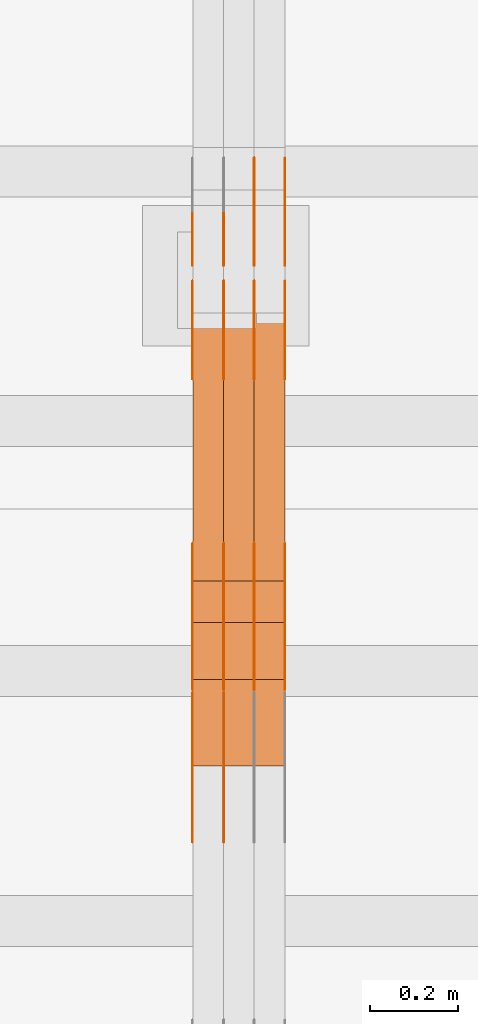
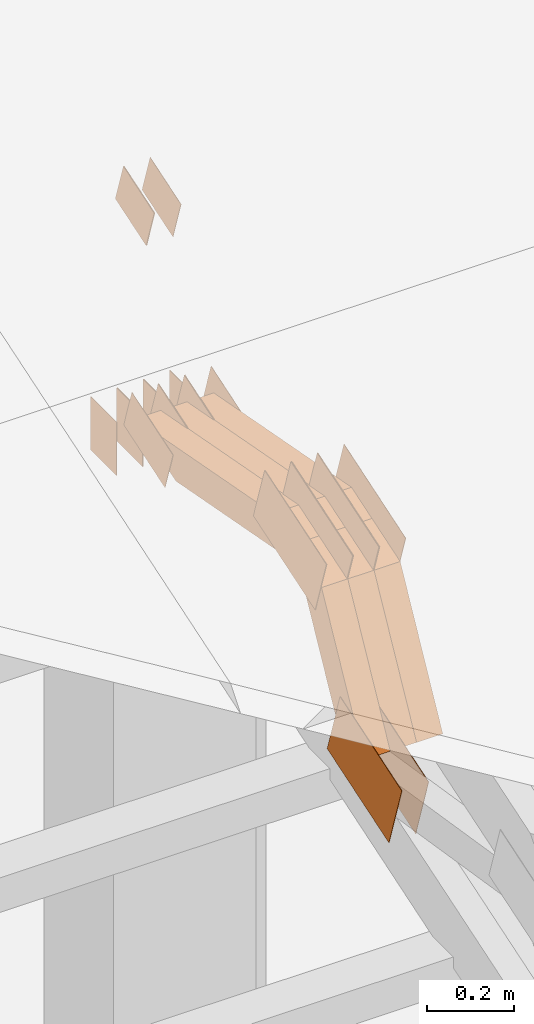
# One storey, part 297 of 385: 29 proxies.
"""IFC2X3 building model written with IfcOpenShell, lengths in millimetres."""

from ifc_helpers import new_model, entity, si_unit, converted_unit, derived_unit, direction, frame, frame_2d, origin, place, context, subcontext, project, spatial, polyline, rectangle, outline, extrude, source, transform, mapped, material, type_object, type_shapes, element, save


model = new_model("IFC2X3")

# Units and contexts
model_context = context("Model", 3, precision=0.01, world=origin(), true_north=direction((6.12303176911189e-17, 1.0)))
body_context = subcontext(model_context, "Body", "Model", "MODEL_VIEW")
ifc_project = project(units=[si_unit("LENGTHUNIT", "METRE", prefix="MILLI"), si_unit("AREAUNIT", "SQUARE_METRE"), si_unit("VOLUMEUNIT", "CUBIC_METRE"), converted_unit("PLANEANGLEUNIT", "DEGREE", entity("IfcRatioMeasure", 0.0174532925199433), si_unit("PLANEANGLEUNIT", "RADIAN"), dimensions=[0, 0, 0, 0, 0, 0, 0]), si_unit("MASSUNIT", "GRAM", prefix="KILO"), derived_unit("MASSDENSITYUNIT", [(si_unit("MASSUNIT", "GRAM", prefix="KILO"), 1), (si_unit("LENGTHUNIT", "METRE"), -3)]), si_unit("TIMEUNIT", "SECOND"), si_unit("FREQUENCYUNIT", "HERTZ"), si_unit("THERMODYNAMICTEMPERATUREUNIT", "DEGREE_CELSIUS"), derived_unit("THERMALTRANSMITTANCEUNIT", [(si_unit("MASSUNIT", "GRAM", prefix="KILO"), 1), (si_unit("THERMODYNAMICTEMPERATUREUNIT", "KELVIN"), -1), (si_unit("TIMEUNIT", "SECOND"), -3)]), derived_unit("VOLUMETRICFLOWRATEUNIT", [(si_unit("LENGTHUNIT", "METRE"), 3), (si_unit("TIMEUNIT", "SECOND"), -1)]), si_unit("ELECTRICCURRENTUNIT", "AMPERE"), si_unit("ELECTRICVOLTAGEUNIT", "VOLT"), si_unit("POWERUNIT", "WATT"), si_unit("FORCEUNIT", "NEWTON", prefix="KILO"), si_unit("ILLUMINANCEUNIT", "LUX"), si_unit("LUMINOUSFLUXUNIT", "LUMEN"), si_unit("LUMINOUSINTENSITYUNIT", "CANDELA"), derived_unit("USERDEFINED", [(si_unit("MASSUNIT", "GRAM", prefix="KILO"), -1), (si_unit("LENGTHUNIT", "METRE"), -2), (si_unit("TIMEUNIT", "SECOND"), 3), (si_unit("LUMINOUSFLUXUNIT", "LUMEN"), 1)]), derived_unit("LINEARVELOCITYUNIT", [(si_unit("LENGTHUNIT", "METRE"), 1), (si_unit("TIMEUNIT", "SECOND"), -1)]), si_unit("PRESSUREUNIT", "PASCAL"), derived_unit("USERDEFINED", [(si_unit("LENGTHUNIT", "METRE"), -2), (si_unit("MASSUNIT", "GRAM", prefix="KILO"), 1), (si_unit("TIMEUNIT", "SECOND"), -2)])], contexts=[model_context])

# Site, building, storey
site_placement = place(None, origin())
site = spatial("IfcSite", under=ifc_project, at=site_placement, CompositionType="ELEMENT")
building_placement = place(site_placement, origin())
building = spatial("IfcBuilding", under=site, at=building_placement, CompositionType="ELEMENT")
storey_placement = place(building_placement, origin())
storey = spatial("IfcBuildingStorey", under=building, at=storey_placement, Name="Default", CompositionType="ELEMENT", Elevation=0.0)

# Proxies
ifc_material_1 = material(Name="IfcSurfaceStyle #552548")
building_element_proxy_type_1 = type_object("IfcBuildingElementProxyType", PredefinedType="NOTDEFINED", material=ifc_material_1)
shared_shape_1 = source(origin(), body_context, "Body", "SweptSolid", [
    extrude(outline(polyline([(-149.99966632326, -95.9999759039407), (149.999881095801, -95.9999759039407), (150.000557367591, 95.9999759039407), (-150.000772140132, 95.9999759039406), (-149.99966632326, -95.9999759039407)])), frame((150.000557367591, 96.0004291135906, 0.0), z_axis=(0.0, 0.0, 1.0), x_axis=(-1.0, 0.0, 0.0)), (0.0, 0.0, 1.0), 1.29999999999998),
])
type_shapes(building_element_proxy_type_1, [shared_shape_1])
proxy_1_placement = place(building_placement, frame((45246.3, 10934.7734375, 2766.8759765625), z_axis=(-1.0, 0.0, 0.0), x_axis=(0.0, 0.951056516295124, 0.309016994375039)))
element("IfcBuildingElementProxy", 1, at=proxy_1_placement, inside=storey, type_object=building_element_proxy_type_1, material=ifc_material_1, context=body_context, shape_type="MappedRepresentation", body=[
    mapped(shared_shape_1, transform((0.0, 0.0, 0.0), scale=1.0)),
])
ifc_material_2 = material(Name="IfcSurfaceStyle #552491")
building_element_proxy_type_2 = type_object("IfcBuildingElementProxyType", PredefinedType="NOTDEFINED", material=ifc_material_2)
shared_shape_2 = source(origin(), body_context, "Body", "SweptSolid", [
    extrude(outline(polyline([(-149.99966632326, -95.9999759039407), (149.999881095801, -95.9999759039407), (150.000557367591, 95.9999759039407), (-150.000772140132, 95.9999759039406), (-149.99966632326, -95.9999759039407)])), frame((150.000557367591, 96.0004291135906, 0.0), z_axis=(0.0, 0.0, 1.0), x_axis=(-1.0, 0.0, 0.0)), (0.0, 0.0, 1.0), 1.29999999999998),
])
type_shapes(building_element_proxy_type_2, [shared_shape_2])
proxy_2_placement = place(building_placement, frame((45175.0, 10934.7734375, 2766.8759765625), z_axis=(-1.0, 0.0, 0.0), x_axis=(0.0, 0.951056516295124, 0.309016994375039)))
element("IfcBuildingElementProxy", 2, at=proxy_2_placement, inside=storey, type_object=building_element_proxy_type_2, material=ifc_material_2, context=body_context, shape_type="MappedRepresentation", body=[
    mapped(shared_shape_2, transform((0.0, 0.0, 0.0), scale=1.0)),
])
ifc_material_3 = material(Name="IfcSurfaceStyle #551408")
building_element_proxy_type_3 = type_object("IfcBuildingElementProxyType", PredefinedType="NOTDEFINED", material=ifc_material_3)
shared_shape_3 = source(origin(), body_context, "Body", "SweptSolid", [
    extrude(outline(polyline([(-99.9997874178038, -60.0000528641967), (99.9998102700997, -60.0000528641967), (99.9998251396068, 60.0000528641967), (-99.9998479919027, 60.0000528641967), (-99.9997874178038, -60.0000528641967)])), frame((99.9999918898597, 60.0000528641967, 0.0), z_axis=(0.0, 0.0, 1.0), x_axis=(-1.0, 0.0, 0.0)), (0.0, 0.0, 1.0), 1.3),
])
type_shapes(building_element_proxy_type_3, [shared_shape_3])
proxy_3_placement = place(building_placement, frame((45386.3, 11991.9568177725, 3072.52282247925), z_axis=(-1.0, 0.0, 0.0), x_axis=(0.0, 0.951056516295124, 0.309016994375039)))
element("IfcBuildingElementProxy", 3, at=proxy_3_placement, inside=storey, type_object=building_element_proxy_type_3, material=ifc_material_3, context=body_context, shape_type="MappedRepresentation", body=[
    mapped(shared_shape_3, transform((0.0, 0.0, 0.0), scale=1.0)),
])
ifc_material_4 = material(Name="IfcSurfaceStyle #551351")
building_element_proxy_type_4 = type_object("IfcBuildingElementProxyType", PredefinedType="NOTDEFINED", material=ifc_material_4)
shared_shape_4 = source(origin(), body_context, "Body", "SweptSolid", [
    extrude(outline(polyline([(-99.9997874178038, -60.0000528641967), (99.9998102700997, -60.0000528641967), (99.9998251396068, 60.0000528641967), (-99.9998479919027, 60.0000528641967), (-99.9997874178038, -60.0000528641967)])), frame((99.9999918898597, 60.0000528641967, 0.0), z_axis=(0.0, 0.0, 1.0), x_axis=(-1.0, 0.0, 0.0)), (0.0, 0.0, 1.0), 1.3),
])
type_shapes(building_element_proxy_type_4, [shared_shape_4])
proxy_4_placement = place(building_placement, frame((45315.0, 11991.9568177725, 3072.52282247925), z_axis=(-1.0, 0.0, 0.0), x_axis=(0.0, 0.951056516295124, 0.309016994375039)))
element("IfcBuildingElementProxy", 4, at=proxy_4_placement, inside=storey, type_object=building_element_proxy_type_4, material=ifc_material_4, context=body_context, shape_type="MappedRepresentation", body=[
    mapped(shared_shape_4, transform((0.0, 0.0, 0.0), scale=1.0)),
])
ifc_material_5 = material(Name="IfcSurfaceStyle #551294")
building_element_proxy_type_5 = type_object("IfcBuildingElementProxyType", PredefinedType="NOTDEFINED", material=ifc_material_5)
shared_shape_5 = source(origin(), body_context, "Body", "SweptSolid", [
    extrude(outline(polyline([(-99.9997874178038, -60.0000528641967), (99.9998102700997, -60.0000528641967), (99.9998251396068, 60.0000528641967), (-99.9998479919027, 60.0000528641967), (-99.9997874178038, -60.0000528641967)])), frame((99.9999918898597, 60.0000528641967, 0.0), z_axis=(0.0, 0.0, 1.0), x_axis=(-1.0, 0.0, 0.0)), (0.0, 0.0, 1.0), 1.3),
])
type_shapes(building_element_proxy_type_5, [shared_shape_5])
proxy_5_placement = place(building_placement, frame((45316.3, 11991.9568177725, 3072.52282247925), z_axis=(-1.0, 0.0, 0.0), x_axis=(0.0, 0.951056516295124, 0.309016994375039)))
element("IfcBuildingElementProxy", 5, at=proxy_5_placement, inside=storey, type_object=building_element_proxy_type_5, material=ifc_material_5, context=body_context, shape_type="MappedRepresentation", body=[
    mapped(shared_shape_5, transform((0.0, 0.0, 0.0), scale=1.0)),
])
ifc_material_6 = material(Name="IfcSurfaceStyle #551237")
building_element_proxy_type_6 = type_object("IfcBuildingElementProxyType", PredefinedType="NOTDEFINED", material=ifc_material_6)
shared_shape_6 = source(origin(), body_context, "Body", "SweptSolid", [
    extrude(outline(polyline([(-99.9997874178038, -60.0000528641967), (99.9998102700997, -60.0000528641967), (99.9998251396068, 60.0000528641967), (-99.9998479919027, 60.0000528641967), (-99.9997874178038, -60.0000528641967)])), frame((99.9999918898597, 60.0000528641967, 0.0), z_axis=(0.0, 0.0, 1.0), x_axis=(-1.0, 0.0, 0.0)), (0.0, 0.0, 1.0), 1.29999999999998),
])
type_shapes(building_element_proxy_type_6, [shared_shape_6])
proxy_6_placement = place(building_placement, frame((45245.0, 11991.9568177725, 3072.52282247925), z_axis=(-1.0, 0.0, 0.0), x_axis=(0.0, 0.951056516295124, 0.309016994375039)))
element("IfcBuildingElementProxy", 6, at=proxy_6_placement, inside=storey, type_object=building_element_proxy_type_6, material=ifc_material_6, context=body_context, shape_type="MappedRepresentation", body=[
    mapped(shared_shape_6, transform((0.0, 0.0, 0.0), scale=1.0)),
])
ifc_material_7 = material(Name="IfcSurfaceStyle #551180")
building_element_proxy_type_7 = type_object("IfcBuildingElementProxyType", PredefinedType="NOTDEFINED", material=ifc_material_7)
shared_shape_7 = source(origin(), body_context, "Body", "SweptSolid", [
    extrude(outline(polyline([(-99.9997874178038, -60.0000528641967), (99.9998102700997, -60.0000528641967), (99.9998251396068, 60.0000528641967), (-99.9998479919027, 60.0000528641967), (-99.9997874178038, -60.0000528641967)])), frame((99.9999918898597, 60.0000528641967, 0.0), z_axis=(0.0, 0.0, 1.0), x_axis=(-1.0, 0.0, 0.0)), (0.0, 0.0, 1.0), 1.29999999999998),
])
type_shapes(building_element_proxy_type_7, [shared_shape_7])
proxy_7_placement = place(building_placement, frame((45246.3, 11991.9568177725, 3072.52282247925), z_axis=(-1.0, 0.0, 0.0), x_axis=(0.0, 0.951056516295124, 0.309016994375039)))
element("IfcBuildingElementProxy", 7, at=proxy_7_placement, inside=storey, type_object=building_element_proxy_type_7, material=ifc_material_7, context=body_context, shape_type="MappedRepresentation", body=[
    mapped(shared_shape_7, transform((0.0, 0.0, 0.0), scale=1.0)),
])
ifc_material_8 = material(Name="IfcSurfaceStyle #551123")
building_element_proxy_type_8 = type_object("IfcBuildingElementProxyType", PredefinedType="NOTDEFINED", material=ifc_material_8)
shared_shape_8 = source(origin(), body_context, "Body", "SweptSolid", [
    extrude(outline(polyline([(-99.9997874178038, -60.0000528641967), (99.9998102700997, -60.0000528641967), (99.9998251396068, 60.0000528641967), (-99.9998479919027, 60.0000528641967), (-99.9997874178038, -60.0000528641967)])), frame((99.9999918898597, 60.0000528641967, 0.0), z_axis=(0.0, 0.0, 1.0), x_axis=(-1.0, 0.0, 0.0)), (0.0, 0.0, 1.0), 1.29999999999999),
])
type_shapes(building_element_proxy_type_8, [shared_shape_8])
proxy_8_placement = place(building_placement, frame((45175.0, 11991.9568177725, 3072.52282247925), z_axis=(-1.0, 0.0, 0.0), x_axis=(0.0, 0.951056516295124, 0.309016994375039)))
element("IfcBuildingElementProxy", 8, at=proxy_8_placement, inside=storey, type_object=building_element_proxy_type_8, material=ifc_material_8, context=body_context, shape_type="MappedRepresentation", body=[
    mapped(shared_shape_8, transform((0.0, 0.0, 0.0), scale=1.0)),
])
ifc_material_9 = material(Name="IfcSurfaceStyle #551066")
building_element_proxy_type_9 = type_object("IfcBuildingElementProxyType", PredefinedType="NOTDEFINED", material=ifc_material_9)
shared_shape_9 = source(origin(), body_context, "Body", "SweptSolid", [
    extrude(rectangle(XDim=150.0, YDim=119.999999999985, at=frame_2d((-7.105427357601e-15, 0.0), x_axis=(1.0, 0.0))), frame((75.0, 60.0, 0.0), z_axis=(0.0, 0.0, 1.0), x_axis=(-1.0, 0.0, 0.0)), (0.0, 0.0, 1.0), 1.3),
])
type_shapes(building_element_proxy_type_9, [shared_shape_9])
proxy_9_placement = place(building_placement, frame((45386.3, 12372.95703125, 3007.04687500001), z_axis=(-1.0, 0.0, 0.0), x_axis=(0.0, 0.0, -1.0)))
element("IfcBuildingElementProxy", 9, at=proxy_9_placement, inside=storey, type_object=building_element_proxy_type_9, material=ifc_material_9, context=body_context, shape_type="MappedRepresentation", body=[
    mapped(shared_shape_9, transform((0.0, 0.0, 0.0), scale=1.0)),
])
ifc_material_10 = material(Name="IfcSurfaceStyle #551009")
building_element_proxy_type_10 = type_object("IfcBuildingElementProxyType", PredefinedType="NOTDEFINED", material=ifc_material_10)
shared_shape_10 = source(origin(), body_context, "Body", "SweptSolid", [
    extrude(rectangle(XDim=150.0, YDim=119.999999999985, at=frame_2d((-7.105427357601e-15, 0.0), x_axis=(1.0, 0.0))), frame((75.0, 60.0, 0.0), z_axis=(0.0, 0.0, 1.0), x_axis=(-1.0, 0.0, 0.0)), (0.0, 0.0, 1.0), 1.3),
])
type_shapes(building_element_proxy_type_10, [shared_shape_10])
proxy_10_placement = place(building_placement, frame((45315.0, 12372.95703125, 3007.04687500001), z_axis=(-1.0, 0.0, 0.0), x_axis=(0.0, 0.0, -1.0)))
element("IfcBuildingElementProxy", 10, at=proxy_10_placement, inside=storey, type_object=building_element_proxy_type_10, material=ifc_material_10, context=body_context, shape_type="MappedRepresentation", body=[
    mapped(shared_shape_10, transform((0.0, 0.0, 0.0), scale=1.0)),
])
ifc_material_11 = material(Name="IfcSurfaceStyle #550952")
building_element_proxy_type_11 = type_object("IfcBuildingElementProxyType", PredefinedType="NOTDEFINED", material=ifc_material_11)
shared_shape_11 = source(origin(), body_context, "Body", "SweptSolid", [
    extrude(rectangle(XDim=150.0, YDim=119.999999999985, at=frame_2d((-7.105427357601e-15, 0.0), x_axis=(1.0, 0.0))), frame((75.0, 60.0, 0.0), z_axis=(0.0, 0.0, 1.0), x_axis=(-1.0, 0.0, 0.0)), (0.0, 0.0, 1.0), 1.3),
])
type_shapes(building_element_proxy_type_11, [shared_shape_11])
proxy_11_placement = place(building_placement, frame((45316.3, 12372.95703125, 3007.04687500001), z_axis=(-1.0, 0.0, 0.0), x_axis=(0.0, 0.0, -1.0)))
element("IfcBuildingElementProxy", 11, at=proxy_11_placement, inside=storey, type_object=building_element_proxy_type_11, material=ifc_material_11, context=body_context, shape_type="MappedRepresentation", body=[
    mapped(shared_shape_11, transform((0.0, 0.0, 0.0), scale=1.0)),
])
ifc_material_12 = material(Name="IfcSurfaceStyle #550895")
building_element_proxy_type_12 = type_object("IfcBuildingElementProxyType", PredefinedType="NOTDEFINED", material=ifc_material_12)
shared_shape_12 = source(origin(), body_context, "Body", "SweptSolid", [
    extrude(rectangle(XDim=150.0, YDim=119.999999999985, at=frame_2d((-7.105427357601e-15, 0.0), x_axis=(1.0, 0.0))), frame((75.0, 60.0, 0.0), z_axis=(0.0, 0.0, 1.0), x_axis=(-1.0, 0.0, 0.0)), (0.0, 0.0, 1.0), 1.29999999999999),
])
type_shapes(building_element_proxy_type_12, [shared_shape_12])
proxy_12_placement = place(building_placement, frame((45245.0, 12372.95703125, 3007.04687500001), z_axis=(-1.0, 0.0, 0.0), x_axis=(0.0, 0.0, -1.0)))
element("IfcBuildingElementProxy", 12, at=proxy_12_placement, inside=storey, type_object=building_element_proxy_type_12, material=ifc_material_12, context=body_context, shape_type="MappedRepresentation", body=[
    mapped(shared_shape_12, transform((0.0, 0.0, 0.0), scale=1.0)),
])
ifc_material_13 = material(Name="IfcSurfaceStyle #550838")
building_element_proxy_type_13 = type_object("IfcBuildingElementProxyType", PredefinedType="NOTDEFINED", material=ifc_material_13)
shared_shape_13 = source(origin(), body_context, "Body", "SweptSolid", [
    extrude(rectangle(XDim=150.0, YDim=119.999999999985, at=frame_2d((-7.105427357601e-15, 0.0), x_axis=(1.0, 0.0))), frame((75.0, 60.0, 0.0), z_axis=(0.0, 0.0, 1.0), x_axis=(-1.0, 0.0, 0.0)), (0.0, 0.0, 1.0), 1.29999999999999),
])
type_shapes(building_element_proxy_type_13, [shared_shape_13])
proxy_13_placement = place(building_placement, frame((45246.3, 12372.95703125, 3007.04687500001), z_axis=(-1.0, 0.0, 0.0), x_axis=(0.0, 0.0, -1.0)))
element("IfcBuildingElementProxy", 13, at=proxy_13_placement, inside=storey, type_object=building_element_proxy_type_13, material=ifc_material_13, context=body_context, shape_type="MappedRepresentation", body=[
    mapped(shared_shape_13, transform((0.0, 0.0, 0.0), scale=1.0)),
])
ifc_material_14 = material(Name="IfcSurfaceStyle #550781")
building_element_proxy_type_14 = type_object("IfcBuildingElementProxyType", PredefinedType="NOTDEFINED", material=ifc_material_14)
shared_shape_14 = source(origin(), body_context, "Body", "SweptSolid", [
    extrude(rectangle(XDim=150.0, YDim=119.999999999985, at=frame_2d((-7.105427357601e-15, 0.0), x_axis=(1.0, 0.0))), frame((75.0, 60.0, 0.0), z_axis=(0.0, 0.0, 1.0), x_axis=(-1.0, 0.0, 0.0)), (0.0, 0.0, 1.0), 1.29999999999999),
])
type_shapes(building_element_proxy_type_14, [shared_shape_14])
proxy_14_placement = place(building_placement, frame((45175.0, 12372.95703125, 3007.04687500001), z_axis=(-1.0, 0.0, 0.0), x_axis=(0.0, 0.0, -1.0)))
element("IfcBuildingElementProxy", 14, at=proxy_14_placement, inside=storey, type_object=building_element_proxy_type_14, material=ifc_material_14, context=body_context, shape_type="MappedRepresentation", body=[
    mapped(shared_shape_14, transform((0.0, 0.0, 0.0), scale=1.0)),
])
ifc_material_15 = material(Name="IfcSurfaceStyle #543884")
building_element_proxy_type_15 = type_object("IfcBuildingElementProxyType", PredefinedType="NOTDEFINED", material=ifc_material_15)
shared_shape_15 = source(origin(), body_context, "Body", "SweptSolid", [
    extrude(outline(polyline([(-74.9998754286244, -60.0000016373506), (74.9998605591063, -60.0000016373506), (74.9998754286244, 60.0000016373506), (-74.9998605591063, 60.0000016373506), (-74.9998754286244, -60.0000016373506)])), frame((74.9998754286244, 60.0000016373506, 0.0), z_axis=(0.0, 0.0, 1.0), x_axis=(-1.0, 0.0, 0.0)), (0.0, 0.0, 1.0), 1.3),
])
type_shapes(building_element_proxy_type_15, [shared_shape_15])
proxy_15_placement = place(building_placement, frame((45386.3, 12321.1620861463, 3506.17707344366), z_axis=(-1.0, 0.0, 0.0), x_axis=(0.0, 0.951056516295154, 0.309016994374948)))
element("IfcBuildingElementProxy", 15, at=proxy_15_placement, inside=storey, type_object=building_element_proxy_type_15, material=ifc_material_15, context=body_context, shape_type="MappedRepresentation", body=[
    mapped(shared_shape_15, transform((0.0, 0.0, 0.0), scale=1.0)),
])
ifc_material_16 = material(Name="IfcSurfaceStyle #543827")
building_element_proxy_type_16 = type_object("IfcBuildingElementProxyType", PredefinedType="NOTDEFINED", material=ifc_material_16)
shared_shape_16 = source(origin(), body_context, "Body", "SweptSolid", [
    extrude(outline(polyline([(-74.9998754286244, -60.0000016373506), (74.9998605591063, -60.0000016373506), (74.9998754286244, 60.0000016373506), (-74.9998605591063, 60.0000016373506), (-74.9998754286244, -60.0000016373506)])), frame((74.9998754286244, 60.0000016373506, 0.0), z_axis=(0.0, 0.0, 1.0), x_axis=(-1.0, 0.0, 0.0)), (0.0, 0.0, 1.0), 1.3),
])
type_shapes(building_element_proxy_type_16, [shared_shape_16])
proxy_16_placement = place(building_placement, frame((45315.0, 12321.1620861463, 3506.17707344366), z_axis=(-1.0, 0.0, 0.0), x_axis=(0.0, 0.951056516295154, 0.309016994374948)))
element("IfcBuildingElementProxy", 16, at=proxy_16_placement, inside=storey, type_object=building_element_proxy_type_16, material=ifc_material_16, context=body_context, shape_type="MappedRepresentation", body=[
    mapped(shared_shape_16, transform((0.0, 0.0, 0.0), scale=1.0)),
])
ifc_material_17 = material(Name="IfcSurfaceStyle #543770")
building_element_proxy_type_17 = type_object("IfcBuildingElementProxyType", PredefinedType="NOTDEFINED", material=ifc_material_17)
shared_shape_17 = source(origin(), body_context, "Body", "SweptSolid", [
    extrude(outline(polyline([(-74.9998754286244, -60.0000016373506), (74.9998605591063, -60.0000016373506), (74.9998754286244, 60.0000016373506), (-74.9998605591063, 60.0000016373506), (-74.9998754286244, -60.0000016373506)])), frame((74.9998754286244, 60.0000016373506, 0.0), z_axis=(0.0, 0.0, 1.0), x_axis=(-1.0, 0.0, 0.0)), (0.0, 0.0, 1.0), 1.3),
])
type_shapes(building_element_proxy_type_17, [shared_shape_17])
proxy_17_placement = place(building_placement, frame((45316.3, 12321.1620861463, 3506.17707344366), z_axis=(-1.0, 0.0, 0.0), x_axis=(0.0, 0.951056516295154, 0.309016994374948)))
element("IfcBuildingElementProxy", 17, at=proxy_17_placement, inside=storey, type_object=building_element_proxy_type_17, material=ifc_material_17, context=body_context, shape_type="MappedRepresentation", body=[
    mapped(shared_shape_17, transform((0.0, 0.0, 0.0), scale=1.0)),
])
ifc_material_18 = material(Name="IfcSurfaceStyle #543200")
building_element_proxy_type_18 = type_object("IfcBuildingElementProxyType", PredefinedType="NOTDEFINED", material=ifc_material_18)
shared_shape_18 = source(origin(), body_context, "Body", "SweptSolid", [
    extrude(outline(polyline([(-150.000273478628, -84.0002987844282), (149.999198496832, -84.0002987844282), (150.000273478627, 84.0002987844282), (-149.999198496831, 84.0002987844282), (-150.000273478628, -84.0002987844282)])), frame((150.000273478627, 84.0002987844282, 0.0), z_axis=(0.0, 0.0, 1.0), x_axis=(-1.0, 0.0, 0.0)), (0.0, 0.0, 1.0), 1.29999999999999),
])
type_shapes(building_element_proxy_type_18, [shared_shape_18])
proxy_18_placement = place(building_placement, frame((45386.3, 11283.0116722926, 3194.09682266857), z_axis=(-1.0, 0.0, 0.0), x_axis=(0.0, 0.951056516295154, 0.309016994374948)))
element("IfcBuildingElementProxy", 18, at=proxy_18_placement, inside=storey, type_object=building_element_proxy_type_18, material=ifc_material_18, context=body_context, shape_type="MappedRepresentation", body=[
    mapped(shared_shape_18, transform((0.0, 0.0, 0.0), scale=1.0)),
])
ifc_material_19 = material(Name="IfcSurfaceStyle #543143")
building_element_proxy_type_19 = type_object("IfcBuildingElementProxyType", PredefinedType="NOTDEFINED", material=ifc_material_19)
shared_shape_19 = source(origin(), body_context, "Body", "SweptSolid", [
    extrude(outline(polyline([(-150.000273478628, -84.0002987844282), (149.999198496832, -84.0002987844282), (150.000273478627, 84.0002987844282), (-149.999198496831, 84.0002987844282), (-150.000273478628, -84.0002987844282)])), frame((150.000273478627, 84.0002987844282, 0.0), z_axis=(0.0, 0.0, 1.0), x_axis=(-1.0, 0.0, 0.0)), (0.0, 0.0, 1.0), 1.29999999999999),
])
type_shapes(building_element_proxy_type_19, [shared_shape_19])
proxy_19_placement = place(building_placement, frame((45315.0, 11283.0116722926, 3194.09682266857), z_axis=(-1.0, 0.0, 0.0), x_axis=(0.0, 0.951056516295154, 0.309016994374948)))
element("IfcBuildingElementProxy", 19, at=proxy_19_placement, inside=storey, type_object=building_element_proxy_type_19, material=ifc_material_19, context=body_context, shape_type="MappedRepresentation", body=[
    mapped(shared_shape_19, transform((0.0, 0.0, 0.0), scale=1.0)),
])
ifc_material_20 = material(Name="IfcSurfaceStyle #543086")
building_element_proxy_type_20 = type_object("IfcBuildingElementProxyType", PredefinedType="NOTDEFINED", material=ifc_material_20)
shared_shape_20 = source(origin(), body_context, "Body", "SweptSolid", [
    extrude(outline(polyline([(-150.000273478628, -84.0002987844282), (149.999198496832, -84.0002987844282), (150.000273478627, 84.0002987844282), (-149.999198496831, 84.0002987844282), (-150.000273478628, -84.0002987844282)])), frame((150.000273478627, 84.0002987844282, 0.0), z_axis=(0.0, 0.0, 1.0), x_axis=(-1.0, 0.0, 0.0)), (0.0, 0.0, 1.0), 1.29999999999999),
])
type_shapes(building_element_proxy_type_20, [shared_shape_20])
proxy_20_placement = place(building_placement, frame((45316.3, 11283.0116722926, 3194.09682266857), z_axis=(-1.0, 0.0, 0.0), x_axis=(0.0, 0.951056516295154, 0.309016994374948)))
element("IfcBuildingElementProxy", 20, at=proxy_20_placement, inside=storey, type_object=building_element_proxy_type_20, material=ifc_material_20, context=body_context, shape_type="MappedRepresentation", body=[
    mapped(shared_shape_20, transform((0.0, 0.0, 0.0), scale=1.0)),
])
ifc_material_21 = material(Name="IfcSurfaceStyle #543029")
building_element_proxy_type_21 = type_object("IfcBuildingElementProxyType", PredefinedType="NOTDEFINED", material=ifc_material_21)
shared_shape_21 = source(origin(), body_context, "Body", "SweptSolid", [
    extrude(outline(polyline([(-150.000273478628, -84.0002987844282), (149.999198496832, -84.0002987844282), (150.000273478627, 84.0002987844282), (-149.999198496831, 84.0002987844282), (-150.000273478628, -84.0002987844282)])), frame((150.000273478627, 84.0002987844282, 0.0), z_axis=(0.0, 0.0, 1.0), x_axis=(-1.0, 0.0, 0.0)), (0.0, 0.0, 1.0), 1.29999999999998),
])
type_shapes(building_element_proxy_type_21, [shared_shape_21])
proxy_21_placement = place(building_placement, frame((45245.0, 11283.0116722926, 3194.09682266857), z_axis=(-1.0, 0.0, 0.0), x_axis=(0.0, 0.951056516295154, 0.309016994374948)))
element("IfcBuildingElementProxy", 21, at=proxy_21_placement, inside=storey, type_object=building_element_proxy_type_21, material=ifc_material_21, context=body_context, shape_type="MappedRepresentation", body=[
    mapped(shared_shape_21, transform((0.0, 0.0, 0.0), scale=1.0)),
])
ifc_material_22 = material(Name="IfcSurfaceStyle #542972")
building_element_proxy_type_22 = type_object("IfcBuildingElementProxyType", PredefinedType="NOTDEFINED", material=ifc_material_22)
shared_shape_22 = source(origin(), body_context, "Body", "SweptSolid", [
    extrude(outline(polyline([(-150.000273478628, -84.0002987844282), (149.999198496832, -84.0002987844282), (150.000273478627, 84.0002987844282), (-149.999198496831, 84.0002987844282), (-150.000273478628, -84.0002987844282)])), frame((150.000273478627, 84.0002987844282, 0.0), z_axis=(0.0, 0.0, 1.0), x_axis=(-1.0, 0.0, 0.0)), (0.0, 0.0, 1.0), 1.29999999999998),
])
type_shapes(building_element_proxy_type_22, [shared_shape_22])
proxy_22_placement = place(building_placement, frame((45246.3, 11283.0116722926, 3194.09682266857), z_axis=(-1.0, 0.0, 0.0), x_axis=(0.0, 0.951056516295154, 0.309016994374948)))
element("IfcBuildingElementProxy", 22, at=proxy_22_placement, inside=storey, type_object=building_element_proxy_type_22, material=ifc_material_22, context=body_context, shape_type="MappedRepresentation", body=[
    mapped(shared_shape_22, transform((0.0, 0.0, 0.0), scale=1.0)),
])
ifc_material_23 = material(Name="IfcSurfaceStyle #542915")
building_element_proxy_type_23 = type_object("IfcBuildingElementProxyType", PredefinedType="NOTDEFINED", material=ifc_material_23)
shared_shape_23 = source(origin(), body_context, "Body", "SweptSolid", [
    extrude(outline(polyline([(-150.000273478628, -84.0002987844282), (149.999198496832, -84.0002987844282), (150.000273478627, 84.0002987844282), (-149.999198496831, 84.0002987844282), (-150.000273478628, -84.0002987844282)])), frame((150.000273478627, 84.0002987844282, 0.0), z_axis=(0.0, 0.0, 1.0), x_axis=(-1.0, 0.0, 0.0)), (0.0, 0.0, 1.0), 1.29999999999998),
])
type_shapes(building_element_proxy_type_23, [shared_shape_23])
proxy_23_placement = place(building_placement, frame((45175.0, 11283.0116722926, 3194.09682266857), z_axis=(-1.0, 0.0, 0.0), x_axis=(0.0, 0.951056516295154, 0.309016994374948)))
element("IfcBuildingElementProxy", 23, at=proxy_23_placement, inside=storey, type_object=building_element_proxy_type_23, material=ifc_material_23, context=body_context, shape_type="MappedRepresentation", body=[
    mapped(shared_shape_23, transform((0.0, 0.0, 0.0), scale=1.0)),
])
ifc_material_24 = material(Name="IfcSurfaceStyle #532904")
building_element_proxy_type_24 = type_object("IfcBuildingElementProxyType", Name="T1-W9 532902", PredefinedType="NOTDEFINED", material=ifc_material_24)
shared_shape_24 = source(origin(), body_context, "Body", "SweptSolid", [
    extrude(outline(polyline([(-287.457507623288, -47.5000268597988), (288.590479960635, -47.5000268597988), (273.55062971372, -2.33146189358546e-05), (186.625054999886, 47.5000385171083), (-461.308657050953, 47.5000385171083), (-287.457507623288, -47.5000268597988)])), frame((288.590945855618, 47.5000968036551, 0.0), z_axis=(0.0, 0.0, 1.0), x_axis=(-1.0, 0.0, 0.0)), (0.0, 0.0, 1.0), 70.0),
])
type_shapes(building_element_proxy_type_24, [shared_shape_24])
proxy_24_placement = place(building_placement, frame((45385.0, 11432.1200855376, 3205.63308612017), z_axis=(-1.0, 0.0, 0.0), x_axis=(0.0, 0.982760503514031, -0.184883186722992)))
element("IfcBuildingElementProxy", 24, at=proxy_24_placement, inside=storey, type_object=building_element_proxy_type_24, material=ifc_material_24, Name="T1-W9", context=body_context, shape_type="MappedRepresentation", body=[
    mapped(shared_shape_24, transform((0.0, 0.0, 0.0), scale=1.0)),
])
ifc_material_25 = material(Name="IfcSurfaceStyle #532838")
building_element_proxy_type_25 = type_object("IfcBuildingElementProxyType", Name="T1-W9 532836", PredefinedType="NOTDEFINED", material=ifc_material_25)
shared_shape_25 = source(origin(), body_context, "Body", "SweptSolid", [
    extrude(outline(polyline([(-287.457507623288, -47.5000268597988), (288.590479960635, -47.5000268597988), (273.55062971372, -2.33146189358546e-05), (186.625054999886, 47.5000385171083), (-461.308657050953, 47.5000385171083), (-287.457507623288, -47.5000268597988)])), frame((288.590945855618, 47.5000968036551, 0.0), z_axis=(0.0, 0.0, 1.0), x_axis=(-1.0, 0.0, 0.0)), (0.0, 0.0, 1.0), 70.0),
])
type_shapes(building_element_proxy_type_25, [shared_shape_25])
proxy_25_placement = place(building_placement, frame((45315.0, 11432.1200855376, 3205.63308612017), z_axis=(-1.0, 0.0, 0.0), x_axis=(0.0, 0.982760503514031, -0.184883186722992)))
element("IfcBuildingElementProxy", 25, at=proxy_25_placement, inside=storey, type_object=building_element_proxy_type_25, material=ifc_material_25, Name="T1-W9", context=body_context, shape_type="MappedRepresentation", body=[
    mapped(shared_shape_25, transform((0.0, 0.0, 0.0), scale=1.0)),
])
ifc_material_26 = material(Name="IfcSurfaceStyle #532772")
building_element_proxy_type_26 = type_object("IfcBuildingElementProxyType", Name="T1-W9 532770", PredefinedType="NOTDEFINED", material=ifc_material_26)
shared_shape_26 = source(origin(), body_context, "Body", "SweptSolid", [
    extrude(outline(polyline([(-287.457507623288, -47.5000268597988), (288.590479960635, -47.5000268597988), (273.55062971372, -2.33146189358546e-05), (186.625054999886, 47.5000385171083), (-461.308657050953, 47.5000385171083), (-287.457507623288, -47.5000268597988)])), frame((288.590945855618, 47.5000968036551, 0.0), z_axis=(0.0, 0.0, 1.0), x_axis=(-1.0, 0.0, 0.0)), (0.0, 0.0, 1.0), 70.0),
])
type_shapes(building_element_proxy_type_26, [shared_shape_26])
proxy_26_placement = place(building_placement, frame((45245.0, 11432.1200855376, 3205.63308612017), z_axis=(-1.0, 0.0, 0.0), x_axis=(0.0, 0.982760503514031, -0.184883186722992)))
element("IfcBuildingElementProxy", 26, at=proxy_26_placement, inside=storey, type_object=building_element_proxy_type_26, material=ifc_material_26, Name="T1-W9", context=body_context, shape_type="MappedRepresentation", body=[
    mapped(shared_shape_26, transform((0.0, 0.0, 0.0), scale=1.0)),
])
ifc_material_27 = material(Name="IfcSurfaceStyle #532508")
building_element_proxy_type_27 = type_object("IfcBuildingElementProxyType", Name="T1-W32 532506", PredefinedType="NOTDEFINED", material=ifc_material_27)
shared_shape_27 = source(origin(), body_context, "Body", "SweptSolid", [
    extrude(outline(polyline([(-312.414547135921, -47.5000544873059), (136.677011757652, -47.5000544873059), (186.250996577889, 0.000369497452627243), (202.753116295831, 47.4998697385796), (-213.26657749545, 47.4998697385796), (-312.414547135921, -47.5000544873059)])), frame((202.753376481939, 47.5001296985553, 0.0), z_axis=(0.0, 0.0, 1.0), x_axis=(-1.0, 0.0, 0.0)), (0.0, 0.0, 1.0), 70.0),
])
type_shapes(building_element_proxy_type_27, [shared_shape_27])
proxy_27_placement = place(building_placement, frame((45385.0, 11110.7808979007, 2747.18129017315), z_axis=(-1.0, 0.0, 0.0), x_axis=(0.0, 0.472919689385906, 0.881105537033526)))
element("IfcBuildingElementProxy", 27, at=proxy_27_placement, inside=storey, type_object=building_element_proxy_type_27, material=ifc_material_27, Name="T1-W32", context=body_context, shape_type="MappedRepresentation", body=[
    mapped(shared_shape_27, transform((0.0, 0.0, 0.0), scale=1.0)),
])
ifc_material_28 = material(Name="IfcSurfaceStyle #532442")
building_element_proxy_type_28 = type_object("IfcBuildingElementProxyType", Name="T1-W32 532440", PredefinedType="NOTDEFINED", material=ifc_material_28)
shared_shape_28 = source(origin(), body_context, "Body", "SweptSolid", [
    extrude(outline(polyline([(-312.414547135921, -47.5000544873059), (136.677011757652, -47.5000544873059), (186.250996577889, 0.000369497452627243), (202.753116295831, 47.4998697385796), (-213.26657749545, 47.4998697385796), (-312.414547135921, -47.5000544873059)])), frame((202.753376481939, 47.5001296985553, 0.0), z_axis=(0.0, 0.0, 1.0), x_axis=(-1.0, 0.0, 0.0)), (0.0, 0.0, 1.0), 70.0),
])
type_shapes(building_element_proxy_type_28, [shared_shape_28])
proxy_28_placement = place(building_placement, frame((45315.0, 11110.7808979007, 2747.18129017315), z_axis=(-1.0, 0.0, 0.0), x_axis=(0.0, 0.472919689385906, 0.881105537033526)))
element("IfcBuildingElementProxy", 28, at=proxy_28_placement, inside=storey, type_object=building_element_proxy_type_28, material=ifc_material_28, Name="T1-W32", context=body_context, shape_type="MappedRepresentation", body=[
    mapped(shared_shape_28, transform((0.0, 0.0, 0.0), scale=1.0)),
])
ifc_material_29 = material(Name="IfcSurfaceStyle #532376")
building_element_proxy_type_29 = type_object("IfcBuildingElementProxyType", Name="T1-W32 532374", PredefinedType="NOTDEFINED", material=ifc_material_29)
shared_shape_29 = source(origin(), body_context, "Body", "SweptSolid", [
    extrude(outline(polyline([(-312.414547135921, -47.5000544873059), (136.677011757652, -47.5000544873059), (186.250996577889, 0.000369497452627243), (202.753116295831, 47.4998697385796), (-213.26657749545, 47.4998697385796), (-312.414547135921, -47.5000544873059)])), frame((202.753376481939, 47.5001296985553, 0.0), z_axis=(0.0, 0.0, 1.0), x_axis=(-1.0, 0.0, 0.0)), (0.0, 0.0, 1.0), 70.0),
])
type_shapes(building_element_proxy_type_29, [shared_shape_29])
proxy_29_placement = place(building_placement, frame((45245.0, 11110.7808979007, 2747.18129017315), z_axis=(-1.0, 0.0, 0.0), x_axis=(0.0, 0.472919689385906, 0.881105537033526)))
element("IfcBuildingElementProxy", 29, at=proxy_29_placement, inside=storey, type_object=building_element_proxy_type_29, material=ifc_material_29, Name="T1-W32", context=body_context, shape_type="MappedRepresentation", body=[
    mapped(shared_shape_29, transform((0.0, 0.0, 0.0), scale=1.0)),
])

save(model, "model.ifc")
